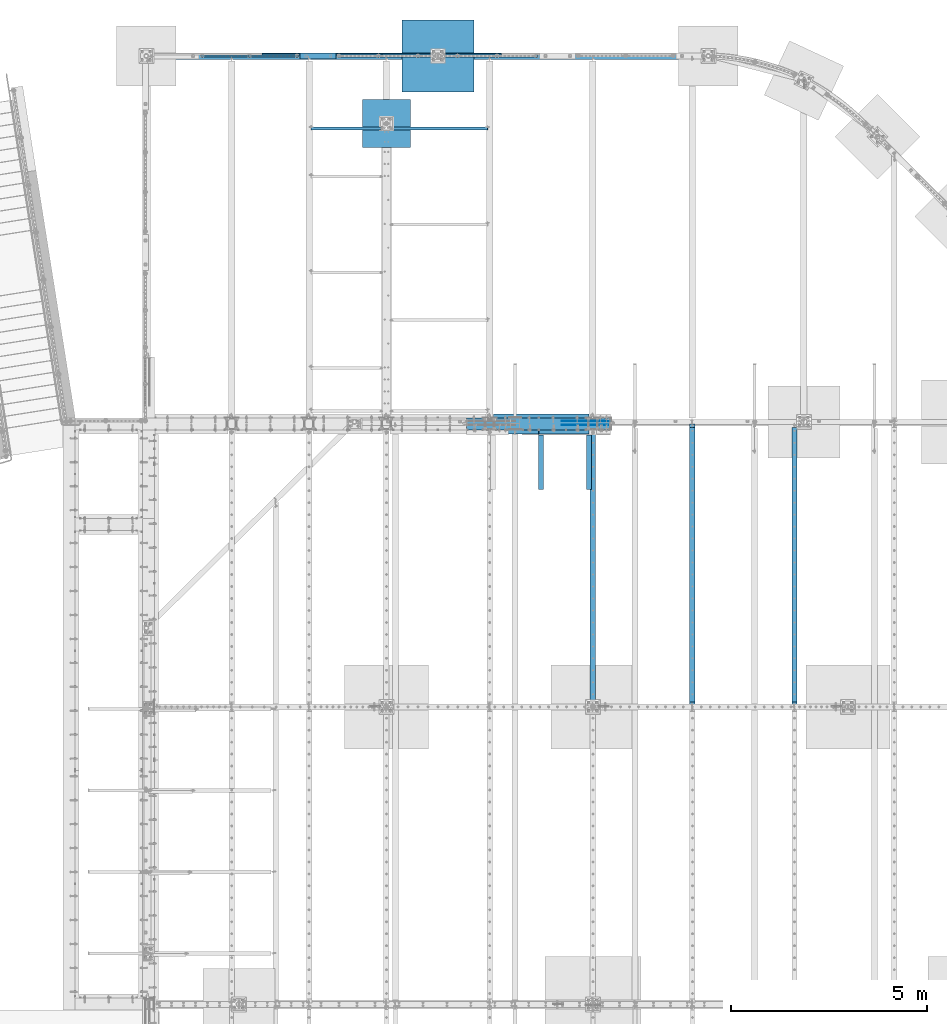
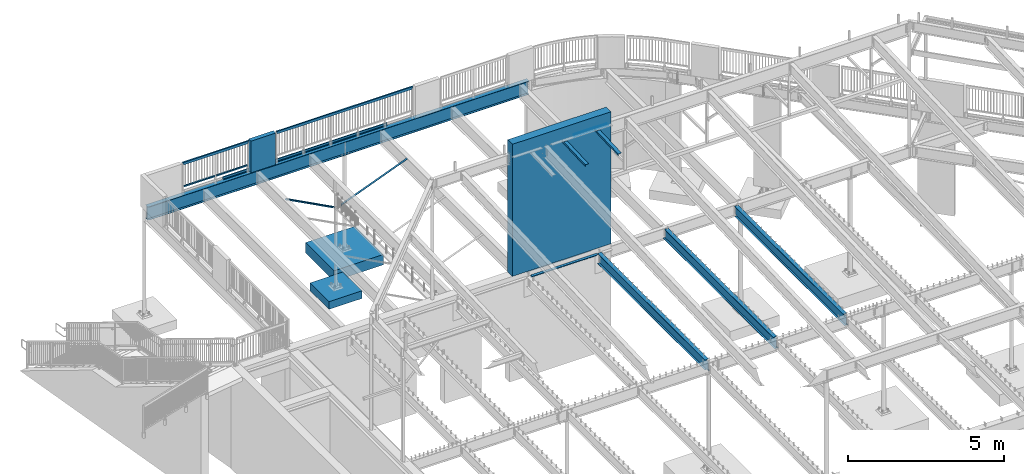
# One storey, part 325 of 975: 23 beams.
"""IFC2X3 building model written with IfcOpenShell, lengths in millimetres."""

from ifc_helpers import new_model, si_unit, frame, origin_with_axes, place, context, subcontext, project, spatial, faceted_brep, material, type_object, element, save


model = new_model("IFC2X3")

# Units and contexts
model_context = context("Model", 3, precision=1e-05, world=origin_with_axes())
body_context = subcontext(model_context, "Body", "Model", "MODEL_VIEW")
ifc_project = project(units=[si_unit("LENGTHUNIT", "METRE", prefix="MILLI"), si_unit("AREAUNIT", "SQUARE_METRE"), si_unit("VOLUMEUNIT", "CUBIC_METRE"), si_unit("MASSUNIT", "GRAM", prefix="KILO"), si_unit("TIMEUNIT", "SECOND"), si_unit("PLANEANGLEUNIT", "RADIAN"), si_unit("SOLIDANGLEUNIT", "STERADIAN"), si_unit("THERMODYNAMICTEMPERATUREUNIT", "DEGREE_CELSIUS"), si_unit("LUMINOUSINTENSITYUNIT", "LUMEN")], contexts=[model_context])

# Site, building, storey
site_placement = place(None, origin_with_axes())
site = spatial("IfcSite", under=ifc_project, at=site_placement, CompositionType="ELEMENT")
building_placement = place(site_placement, origin_with_axes())
building = spatial("IfcBuilding", under=site, at=building_placement, Name="Undefined", CompositionType="ELEMENT")
storey_placement = place(building_placement, origin_with_axes())
storey = spatial("IfcBuildingStorey", under=building, at=storey_placement, Name="Undefined", CompositionType="ELEMENT", Elevation=0.0)

# Beams
ifc_material_1 = material(Name="STEEL/A36")
beam_type_1 = type_object("IfcBeamType", Name="L3X3X3/16", PredefinedType="NOTDEFINED")
beam_1_placement = place(storey_placement, frame((8064.5, 28112.24375, 2870.2), z_axis=(-0.999999999999998, 6.90000001668524e-08, 0.0), x_axis=(0.0, 0.0, 1.0)))
element("IfcBeam", 1, at=beam_1_placement, inside=storey, type_object=beam_type_1, material=ifc_material_1, Name="ANGLE", ObjectType="L3X3X3/16", context=body_context, shape_type="Brep", body=[
    faceted_brep([(46.1799589858119, 38.0999999999985, 38.1000000000004), (46.1799589858119, 33.3375000000015, 38.1000000000004), (972.720343066658, 33.3375000000015, 1789.57301067668), (972.720343066658, 38.0999999999985, 1789.57301067668), (26.0603826014149, 38.0999999999985, 0.0672324894812846), (26.0603826014149, 33.3375000000015, 0.0672324894812846), (89.2065642251332, 38.0999999999985, -33.3374999984389), (89.2065642251332, 33.3375000000015, -33.3374999984389), (1035.86652469034, 33.3375000000015, 1756.16827818882), (89.2065642281518, -38.0999999999985, -33.3374999999996), (1035.86652469042, -38.0999999999985, 1756.16827818877), (25.4000000000001, -38.0999999999985, -33.3374999999996), (25.4000000000001, -38.0999999999985, -38.1000000000004), (92.0750045776413, -38.0999999999985, -38.1000000000004), (1040.07627013201, -38.0999999999985, 1753.94129602291), (92.0750045776413, 38.0999999999985, -38.1000000000004), (25.4000000000001, 38.0999999999985, -38.1000000000004), (1040.07627013201, 38.0999999999985, 1753.94129602291), (25.4000000000001, 38.0999999999985, -33.337499282643), (25.4000000000001, 33.3375000000015, -33.3374999999996)], [[[0, 1, 2, 3]], [[1, 0, 4, 5]], [[5, 4, 6, 7]], [[1, 5, 7, 8, 2]], [[7, 9, 10, 8]], [[9, 11, 12, 13, 14, 10]], [[15, 13, 12, 16]], [[13, 15, 17, 14]], [[3, 2, 8, 10, 14, 17]], [[15, 16, 18, 6, 4, 0, 3, 17]], [[7, 6, 18, 19]], [[16, 12, 11, 19, 18]], [[9, 7, 19, 11]]]),
])
beam_2_placement = place(storey_placement, frame((8394.7, 28112.24375, 2870.2), z_axis=(0.0, -1.0, 0.0), x_axis=(0.0, 0.0, 1.0)))
element("IfcBeam", 2, at=beam_2_placement, inside=storey, type_object=beam_type_1, material=ifc_material_1, Name="ANGLE", ObjectType="L3X3X3/16", context=body_context, shape_type="Brep", body=[
    faceted_brep([(39.9761162779782, -38.1000000000186, -33.3375000000015), (39.9761162779782, -38.1000000000186, -38.0999999999985), (975.885837340196, -2441.28615210523, -38.0999999999985), (975.885837340196, -2441.28615210523, -33.3375000000015), (92.0750045805971, 38.0999999999585, 38.0999999999985), (92.0750045776413, 38.0999999999985, -38.1000000000004), (25.4000000000001, 38.0999999999985, -38.1000000000004), (25.4000000005876, 38.0999999999876, 38.0999999999985), (1046.89123738925, -2413.6334277571, 38.0999999999985), (1046.89123738925, -2413.6334277571, -38.0999999999985), (22.2348571728535, 7.45519597605016, -38.0999999999985), (88.8737698161085, 33.4074081533654, -38.0999999999985), (25.4037304659755, 33.357482595593, -38.0999999999985), (88.8737698161085, 33.4074081533654, -33.3375000000015), (22.2348571728535, 7.45519597605016, -33.3375000000015), (25.4037304659819, 33.3574825875421, -33.3375000000015), (25.4037304659746, 33.3574825966371, 38.0999999999985), (88.8188240616832, 33.3374999999596, 38.0999999999985), (1042.45405198512, -2415.36146907195, -33.3375000000015), (1042.45339988618, -2415.36172302886, 38.0999999999985)], [[[0, 1, 2, 3]], [[4, 5, 6, 7]], [[5, 4, 8, 9]], [[1, 10, 11, 12, 6, 5, 9, 2]], [[13, 11, 10, 14]], [[11, 13, 15, 12]], [[16, 7, 6, 12, 15]], [[13, 17, 16, 15]], [[17, 13, 18, 19]], [[4, 7, 16, 17, 19, 8]], [[18, 3, 2, 9, 8, 19]], [[13, 14, 0, 3, 18]], [[10, 1, 0, 14]]]),
])
ifc_material_2 = material()
beam_type_2 = type_object("IfcBeamType", Name="HSS2X2X.188_TUBES", PredefinedType="NOTDEFINED")
beam_3_placement = place(storey_placement, frame((4746.62715136731, 29961.6867937508, 4229.09979176158), z_axis=(4.55899999906251e-06, 0.999999999989608, 0.0), x_axis=(0.999999999989593, -4.55899999895318e-06, 1.72999999958954e-07)))
element("IfcBeam", 3, at=beam_3_placement, inside=storey, type_object=beam_type_2, material=ifc_material_2, Name="HANDRAIL", ObjectType="HSS2X2X.188_TUBES", context=body_context, shape_type="Brep", body=[
    faceted_brep([(25.3999997357314, 20.6374999999898, -20.6374999999998), (25.4001244344508, -20.6375000000044, -20.6375000000025), (1181.10374119046, -20.6375000005246, -20.6374999983855), (1181.10373404989, 20.637499999475, -20.6374999983527), (25.3998894558863, -20.6375000000044, 20.6375), (1181.10355301781, -20.6375000005255, 20.6375000015942), (25.3999075342581, 20.6374999999998, 20.6375000000003), (1181.10354587724, 20.637499999475, 20.6375000016269), (25.4000643904665, 25.3999999999887, -25.3999999999287), (25.3998825073104, 25.4000000000005, 25.4000000000005), (1181.1035233411, 25.3999999994758, 25.4000000016276), (1181.10375493821, 25.3999999994758, -25.3999999983462), (25.3998602570064, -25.4000000000033, 25.4000000000001), (1181.1035321295, -25.4000000005253, 25.4000000015876), (25.4001494613913, -25.4000000000042, -25.4000000000028), (1181.10376372661, -25.4000000005253, -25.3999999983862)], [[[0, 1, 2, 3]], [[1, 4, 5, 2]], [[4, 6, 7, 5]], [[6, 0, 3, 7]], [[8, 9, 10, 11]], [[9, 12, 13, 10]], [[12, 14, 15, 13]], [[14, 8, 11, 15]], [[13, 15, 11, 10], [5, 7, 3, 2]], [[14, 12, 9, 8], [6, 4, 1, 0]]]),
])
beam_4_placement = place(storey_placement, frame((3540.12495572627, 29961.6977934874, 4229.10021524384), z_axis=(4.55899999906251e-06, 0.999999999989608, 0.0), x_axis=(0.999999999989593, -4.55899999895318e-06, 1.72999999958954e-07)))
element("IfcBeam", 4, at=beam_4_placement, inside=storey, type_object=beam_type_2, material=ifc_material_2, Name="HANDRAIL", ObjectType="HSS2X2X.188_TUBES", context=body_context, shape_type="Brep", body=[
    faceted_brep([(25.4001425128263, 20.6374999999998, -20.6375000000021), (25.4001244344508, -20.6375000000044, -20.6375000000025), (1181.10227410721, -20.6374999995523, -20.6374999983345), (1181.10225396503, 20.6375000004509, -20.6374999983964), (25.3998894558863, -20.6375000000044, 20.6375), (1181.10208593455, -20.6374999995523, 20.6375000016451), (25.3999075342581, 20.6374999999998, 20.6375000000003), (1181.10206579236, 20.6375000004509, 20.6375000015796), (25.4001717116989, 25.3999999999996, -25.4000000000026), (25.3998825073104, 25.4000000000005, 25.4000000000005), (1181.10204175603, 25.4000000004507, 25.4000000015731), (1181.10227335317, 25.4000000004507, -25.3999999984007), (25.3998602570064, -25.4000000000033, 25.4000000000001), (1181.10206654641, -25.3999999995522, 25.4000000016531), (25.4001494613913, -25.4000000000042, -25.4000000000028), (1181.10229814354, -25.3999999995522, -25.3999999983207)], [[[0, 1, 2, 3]], [[1, 4, 5, 2]], [[4, 6, 7, 5]], [[6, 0, 3, 7]], [[8, 9, 10, 11]], [[9, 12, 13, 10]], [[12, 14, 15, 13]], [[14, 8, 11, 15]], [[13, 15, 11, 10], [5, 7, 3, 2]], [[14, 12, 9, 8], [6, 4, 1, 0]]]),
])
beam_type_3 = type_object("IfcBeamType", Name="HSS2X4X.188_TUBES", PredefinedType="NOTDEFINED")
beam_5_placement = place(storey_placement, frame((3540.124968888, 29961.8003208815, 5130.8), z_axis=(0.0, 0.0, 1.0), x_axis=(0.999999998764607, -4.97069999879304e-05, -1.40000005822416e-08)))
element("IfcBeam", 5, at=beam_5_placement, inside=storey, type_object=beam_type_3, material=ifc_material_2, Name="GUARDRAIL", ObjectType="HSS2X4X.188_TUBES", context=body_context, shape_type="Brep", body=[
    faceted_brep([(23.0198915490837, 20.6374999999994, -46.0375000000031), (23.0198915283145, -20.6374999999966, -46.0375000000085), (2389.98594351881, -20.6375000042608, -46.0375000000004), (2389.98594351874, 20.6374999957952, -46.0375000000004), (-23.0198845522937, -20.6374999999985, 46.0375000000058), (2436.02571436495, -20.6375000043408, 46.0375000000004), (-23.0198845315244, 20.6374999999973, 46.0375000000113), (2436.02571436488, 20.6374999957152, 46.0375000000004), (25.4012592797953, 25.399999999999, -50.8000000000029), (-25.4012522574303, 25.3999999999967, 50.800000000012), (2438.40708182243, 25.3999999957196, 50.8000000000002), (2387.60457606117, 25.3999999958141, -50.8000000000002), (-25.401252282998, -25.3999999999983, 50.8000000000056), (2438.40708182252, -25.4000000043561, 50.8000000000002), (25.401259254224, -25.399999999996, -50.8000000000102), (2387.60457606126, -25.4000000042615, -50.8000000000002)], [[[0, 1, 2, 3]], [[1, 4, 5, 2]], [[4, 6, 7, 5]], [[6, 0, 3, 7]], [[8, 9, 10, 11]], [[9, 12, 13, 10]], [[12, 14, 15, 13]], [[14, 8, 11, 15]], [[13, 15, 11, 10], [5, 7, 3, 2]], [[14, 12, 9, 8], [6, 4, 1, 0]]]),
])
beam_6_placement = place(storey_placement, frame((7019.92795603858, 29962.444542395, 5130.79170626117), z_axis=(0.0, 0.0, 1.0), x_axis=(0.999999996531638, -8.32869999612161e-05, 0.0)))
element("IfcBeam", 6, at=beam_6_placement, inside=storey, type_object=beam_type_3, material=ifc_material_2, Name="GUARDRAIL", ObjectType="HSS2X4X.188_TUBES", context=body_context, shape_type="Brep", body=[
    faceted_brep([(23.0206677038004, 20.6375000000444, -46.0375000000004), (23.0206677037631, -20.6375000000116, -46.0375000000004), (5006.17935668326, -20.6374999959335, -46.0375000000004), (5006.1793566833, 20.6375000041226, -46.0375000000004), (-23.0206664766065, -20.6375000000517, 46.0375000000004), (5052.22069086364, -20.6374999958971, 46.0375000000004), (-23.0206664765683, 20.637500000008, 46.0375000000004), (5052.22069086367, 20.6375000041589, 46.0375000000004), (25.4021160234788, 25.4000000000524, -50.8000000000002), (-25.4021147962385, 25.4000000000087, 50.8000000000002), (5054.60213918335, 25.4000000041669, 50.8000000000002), (5003.79790836363, 25.4000000041269, -50.8000000000002), (-25.4021147962858, -25.4000000000597, 50.8000000000002), (5054.6021391833, -25.3999999959015, 50.8000000000002), (25.4021160234333, -25.4000000000196, -50.8000000000002), (5003.79790836359, -25.3999999959415, -50.8000000000002)], [[[0, 1, 2, 3]], [[1, 4, 5, 2]], [[4, 6, 7, 5]], [[6, 0, 3, 7]], [[8, 9, 10, 11]], [[9, 12, 13, 10]], [[12, 14, 15, 13]], [[14, 8, 11, 15]], [[13, 15, 11, 10], [5, 7, 3, 2]], [[14, 12, 9, 8], [6, 4, 1, 0]]]),
])
beam_type_4 = type_object("IfcBeamType", PredefinedType="NOTDEFINED")
for number, where, z_axis, x_axis, name in (
    (7, (9636.20341487034, 29987.8750007629, 3938.58749694824), (1.0, 0.0, 0.0), (0.0, 1.0, 0.0), "DECK_EDGE"),
    (8, (6588.20341487034, 29987.8750007629, 3938.58749694824), (1.0, 0.0, 0.0), (0.0, 1.0, 0.0), "DECK_EDGE"),
):
    element("IfcBeam", number, at=place(storey_placement, frame(where, z_axis=z_axis, x_axis=x_axis)), inside=storey, type_object=beam_type_4, material=ifc_material_1, Name=name, context=body_context, shape_type="Brep", body=[
        faceted_brep([(1.03318598121405e-09, -1.58750000000009, -1524.00000000109), (-1.04046193882823e-09, -1.58750000000009, 1524.0000000011), (-1.04046193882823e-09, 1.58750000000009, 1524.0000000011), (1.03318598121405e-09, 1.58750000000009, -1524.00000000109), (47.6250001214066, 1.58750000000009, 1524.00000000113), (47.6250001235167, 1.58750000000009, -1524.00000000107), (50.8000001235196, -1.58750000000009, -1524.00000000106), (50.8000001214168, -1.58750000000009, 1524.00000000113), (47.6250001214503, 96.837499999901, 1524.00000000113), (47.625000123473, 96.8374999999951, -1524.00000000106), (50.8000001234759, 104.502628762961, -1524.00000000106), (50.8000001214605, 104.502628762867, 1524.00000000113), (38.6447461584321, 87.8572448731024, 1524.00000000113), (38.6447461604548, 87.8572448731024, -1524.00000000107), (36.3996819826862, 90.102308757891, 1524.00000000112), (36.3996819847016, 90.102308757891, -1524.00000000107)], [[[0, 1, 2, 3]], [[3, 2, 4, 5]], [[1, 0, 6, 7]], [[5, 4, 8, 9]], [[7, 6, 10, 11]], [[9, 8, 12, 13]], [[8, 4, 2, 1, 7, 11, 14, 12]], [[11, 10, 15, 14]], [[10, 6, 0, 3, 5, 9, 13, 15]], [[14, 15, 13, 12]]]),
    ])
ifc_material_3 = material(Name="CONCRETE/5000")
beam_type_5 = type_object("IfcBeamType", PredefinedType="NOTDEFINED")
beam_7_placement = place(storey_placement, frame((6028.87677609106, 29962.4750000005, 4559.3), z_axis=(0.0, 0.0, 1.0), x_axis=(1.0, 0.0, 0.0)))
element("IfcBeam", 9, at=beam_7_placement, inside=storey, type_object=beam_type_5, material=ifc_material_3, Name="LOW WALL", context=body_context, shape_type="Brep", body=[
    faceted_brep([(1.0550138540566e-10, 76.1999999999316, -622.3), (1.0550138540566e-10, 76.1999999999316, 622.3), (914.399999999998, 76.1999999999998, 622.3), (914.399999999998, 76.1999999999998, -622.3), (-1.01863406598568e-10, -76.1999999999243, 622.3), (914.399999999998, -76.2, 622.3), (-1.01863406598568e-10, -76.1999999999243, -622.3), (914.399999999998, -76.2, -622.3)], [[[0, 1, 2, 3]], [[1, 4, 5, 2]], [[4, 6, 7, 5]], [[6, 0, 3, 7]], [[5, 7, 3, 2]], [[6, 4, 1, 0]]]),
])
beam_type_6 = type_object("IfcBeamType", Name="L4X4X5/16", PredefinedType="NOTDEFINED")
for number, where, z_axis, x_axis, name in (
    (10, (13392.149999995, 20799.4249996637, 3886.2), (0.0, 1.0, 0.0), (-0.999999999999998, 6.90000001668524e-08, 0.0), "LEDGER_ANGLE"),
    (11, (10953.7499999909, 20393.025, 3886.2), (0.0, -1.0, 0.0), (1.0, 0.0, 0.0), "LEDGER_ANGLE"),
):
    element("IfcBeam", number, at=place(storey_placement, frame(where, z_axis=z_axis, x_axis=x_axis)), inside=storey, type_object=beam_type_6, material=ifc_material_1, Name=name, ObjectType="L4X4X5/16", context=body_context, shape_type="Brep", body=[
        faceted_brep([(-1.90993887372315e-11, 50.8000000000002, -50.8), (2.00088834390044e-11, 50.8000000000002, 50.8), (2438.40000000415, 50.8000000000002, 50.7999999999993), (2438.40000000415, 50.8000000000002, -50.7999999999993), (2.00088834390044e-11, 42.8625000000002, 50.8), (2438.40000000415, 42.8625000000002, 50.7999999999993), (-1.63709046319127e-11, 42.8625000000002, -42.8625), (2438.40000000415, 42.8625000000002, -42.8624999999993), (-1.63709046319127e-11, -50.8000000000002, -42.8625), (2438.40000000415, -50.8000000000002, -42.8624999999993), (-1.90993887372315e-11, -50.8000000000002, -50.8), (2438.40000000415, -50.8000000000002, -50.7999999999993)], [[[0, 1, 2, 3]], [[1, 4, 5, 2]], [[4, 6, 7, 5]], [[6, 8, 9, 7]], [[8, 10, 11, 9]], [[10, 0, 3, 11]], [[5, 7, 9, 11, 3, 2]], [[10, 8, 6, 4, 1, 0]]]),
    ])
beam_type_7 = type_object("IfcBeamType", Name="L5X3X5/16", PredefinedType="NOTDEFINED")
for number, where, z_axis, x_axis, name in (
    (12, (13384.2125, 18922.6835815429, 8738.420951846), (1.0, 0.0, 0.0), (0.0, 0.999153014665285, 0.0411491589862177), "ANGLE"),
    (13, (12165.0125, 18922.6835815429, 8738.42095184597), (1.0, 0.0, 0.0), (0.0, 0.999153014665285, 0.0411491589862177), "ANGLE"),
):
    element("IfcBeam", number, at=place(storey_placement, frame(where, z_axis=z_axis, x_axis=x_axis)), inside=storey, type_object=beam_type_7, material=ifc_material_1, Name=name, ObjectType="L5X3X5/16", context=body_context, shape_type="Brep", body=[
        faceted_brep([(1395.30358400897, 38.0999999993073, 63.5), (1394.97671549211, 30.1624999993064, 63.5), (1394.97670561824, 30.1624999993055, -55.5625), (1394.97670495998, 30.1624990542159, -63.5), (1395.30357345898, 38.0999999993073, -63.5), (1501.24906497065, 25.7857737940658, -55.5625), (1501.24906431239, 25.785773821176, -63.5), (1513.41947380123, 12.5737820912245, -55.5625), (1513.41947314297, 12.5737821183347, -63.5), (1511.34756340183, -38.1000000007598, -55.5625), (1511.34756274358, -38.1000000007589, -63.5), (5.0931703299284e-11, -38.0999999999999, -63.5000000000255), (2.27373675443232e-12, -38.1000000000313, -55.5624999999873), (3.41060513164848e-12, 30.1624999999367, -55.5625000000091), (-3.63797880709171e-12, 30.1625000000404, 63.4999999999909), (-4.72937244921923e-11, 38.0999999999999, 63.5000000000182), (5.0931703299284e-11, 38.0999999999999, -63.5000000000255)], [[[0, 1, 2, 3, 4]], [[5, 6, 3, 2]], [[7, 8, 6, 5]], [[9, 10, 8, 7]], [[11, 12, 13, 14, 15, 16]], [[14, 13, 2, 1]], [[15, 14, 1, 0]], [[16, 15, 0, 4]], [[11, 16, 4, 3, 6, 8, 10]], [[12, 11, 10, 9]], [[2, 13, 12, 9, 7, 5]]]),
    ])
ifc_material_4 = material(Name="STEEL/A496")
beam_type_8 = type_object("IfcBeamType", Name="#6 DBA", PredefinedType="NOTDEFINED")
for number, where, z_axis, x_axis, name in (
    (14, (13909.6749909893, 20672.4250016253, 8707.44741323086), (0.0, 1.0, 0.0), (-0.999999999999998, 6.90000001668524e-08, 0.0), "ROD"),
    (15, (13909.6749905832, 20570.8250016253, 8707.44741324703), (0.0, 1.0, 0.0), (-0.999999999999998, 6.90000001668524e-08, 0.0), "ROD"),
    (16, (13909.6749909893, 20672.4250016075, 8618.54742535521), (0.0, 1.0, 0.0), (-0.999999999999998, 6.90000001668524e-08, 0.0), "ROD"),
):
    element("IfcBeam", number, at=place(storey_placement, frame(where, z_axis=z_axis, x_axis=x_axis)), inside=storey, type_object=beam_type_8, material=ifc_material_4, Name=name, ObjectType="#6 DBA", context=body_context, shape_type="Brep", body=[
        faceted_brep([(0.0, -6.34999999998763, -3.63797880709171e-12), (0.0, -4.49012806052269, -4.49012806054634), (1219.19983372321, -4.49012806053543, -4.49012805836537), (1219.19983372321, -6.35000000000036, 2.16823536902666e-09), (0.0, 7.27595761418343e-12, -6.35000000000764), (1219.19983372321, 0.0, -6.34999999783395), (0.0, 4.49012806053724, -4.49012806053906), (1219.19983372321, 4.49012806053543, -4.49012805836537), (0.0, 6.34999999999491, 5.45696821063757e-12), (1219.19983372321, 6.35000000000036, 2.16823536902666e-09), (0.0, 4.49012806052633, 4.49012806054634), (1219.19983372321, 4.49012806053543, 4.49012806270184), (0.0, 0.0, 6.35000000000764), (1219.19983372321, 0.0, 6.35000000216678), (0.0, -4.49012806053361, 4.49012806053543), (1219.19983372321, -4.49012806053543, 4.49012806270184)], [[[0, 1, 2, 3]], [[1, 4, 5, 2]], [[4, 6, 7, 5]], [[6, 8, 9, 7]], [[8, 10, 11, 9]], [[10, 12, 13, 11]], [[12, 14, 15, 13]], [[14, 0, 3, 15]], [[5, 7, 9, 11, 13, 15, 3, 2]], [[14, 12, 10, 8, 6, 4, 1, 0]]]),
    ])
ifc_material_5 = material(Name="STEEL/A992")
beam_type_9 = type_object("IfcBeamType", Name="W16X26", PredefinedType="NOTDEFINED")
beam_8_placement = place(storey_placement, frame((18618.2, 13392.15, 3736.975), z_axis=(0.0, 0.0, 1.0), x_axis=(0.0, 1.0, 0.0)))
element("IfcBeam", 17, at=beam_8_placement, inside=storey, type_object=beam_type_9, material=ifc_material_5, Name="BEAM", ObjectType="W16X26", context=body_context, shape_type="Brep", body=[
    faceted_brep([(7098.61634971727, -3.17499999999927, -190.5), (7098.61634971727, -69.8499999999985, -190.5), (7098.61634971727, -69.8499999999985, -200.025), (7098.61634971727, 69.8499999999985, -200.025), (7098.61634971727, 69.8499999999985, -190.5), (7098.61634971727, 3.17499999999927, -190.5), (7098.61634971727, 3.17499999999927, -187.324999809266), (7098.61634971727, -3.17499999999927, -187.324999809266), (7099.58307963985, 3.17499999999927, -182.46492029122), (7099.58307963985, -3.17499999999927, -182.46492029122), (7102.33609354033, 3.17499999999927, -178.344743823066), (7102.33609354033, -3.17499999999927, -178.344743823066), (7106.45627000849, 3.17499999999927, -175.591729922588), (7106.45627000849, -3.17499999999927, -175.591729922588), (7111.31634952653, 3.17499999999927, -174.625), (7111.31634952653, -3.17499999999927, -174.625), (7200.21634971727, -3.17499999999927, -174.625), (7200.21634971727, 3.17499999999927, -174.625), (7111.31634971726, 69.8499999999985, 190.5), (7111.31634971726, 3.17499999999927, 190.5), (118.268749999994, 3.17499999999927, 190.5), (118.268749999994, 69.8499999999985, 190.5), (29.368749999996, 3.17499999999927, -190.5), (29.368749999996, 69.8499999999985, -190.5), (29.368749999996, 69.8499999999985, -200.025), (29.368749999996, -69.8499999999985, -200.025), (29.368749999996, -69.8499999999985, -190.5), (29.368749999996, -3.17499999999927, -190.5), (29.368749999996, -3.17499999999927, 174.625), (29.368749999996, 3.17499999999927, 174.625), (105.568750190729, -3.17499999999927, 174.625), (105.568750190729, 3.17499999999927, 174.625), (110.428829708775, -3.17499999999927, 175.591729922588), (110.428829708775, 3.17499999999927, 175.591729922588), (114.549006176929, -3.17499999999927, 178.344743823066), (114.549006176929, 3.17499999999927, 178.344743823066), (117.302020077406, -3.17499999999927, 182.46492029122), (117.302020077406, 3.17499999999927, 182.46492029122), (118.268749999994, -3.17499999999927, 187.324999809266), (118.268749999994, 3.17499999999927, 187.324999809266), (118.268749999994, -69.8499999999985, 200.024999810586), (118.268749999994, 69.8499999999985, 200.025), (118.268749999994, -3.17499999999927, 190.5), (118.268749999994, -69.8499999999985, 190.5), (7111.31634971726, -3.17499999999927, 190.5), (7111.31634971726, -69.8499999999985, 190.5), (7111.31634971726, -69.8499999999985, 200.025), (7111.31634971726, 69.8499999999985, 200.025), (7111.31634971726, -3.17499999999927, 187.324999809265), (7111.31634971726, 3.17499999999927, 187.324999809265), (7112.28307963985, -3.17499999999927, 182.464920291219), (7112.28307963985, 3.17499999999927, 182.464920291219), (7115.03609354033, -3.17499999999927, 178.344743823066), (7115.03609354033, 3.17499999999927, 178.344743823066), (7119.15627000848, -3.17499999999927, 175.591729922588), (7119.15627000848, 3.17499999999927, 175.591729922588), (7124.01634952653, -3.17499999999927, 174.625), (7124.01634952653, 3.17499999999927, 174.625), (7200.21634971727, -3.17499999999927, 174.625), (7200.21634971727, 3.17499999999927, 174.625)], [[[0, 1, 2, 3, 4, 5, 6, 7]], [[7, 6, 8, 9]], [[9, 8, 10, 11]], [[11, 10, 12, 13]], [[13, 12, 14, 15]], [[16, 15, 14, 17]], [[18, 19, 20, 21]], [[22, 23, 24, 25, 26, 27, 28, 29]], [[30, 31, 29, 28]], [[32, 33, 31, 30]], [[34, 35, 33, 32]], [[36, 37, 35, 34]], [[38, 39, 37, 36]], [[40, 41, 21, 20, 39, 38, 42, 43]], [[44, 45, 43, 42]], [[45, 46, 40, 43]], [[46, 47, 41, 40]], [[47, 18, 21, 41]], [[46, 45, 44, 48, 49, 19, 18, 47]], [[50, 51, 49, 48]], [[52, 53, 51, 50]], [[54, 55, 53, 52]], [[56, 57, 55, 54]], [[58, 59, 57, 56]], [[59, 58, 16, 17]], [[12, 10, 8, 6, 5, 22, 29, 31, 33, 35, 37, 39, 20, 19, 49, 51, 53, 55, 57, 59, 17, 14]], [[23, 22, 5, 4]], [[24, 23, 4, 3]], [[25, 24, 3, 2]], [[26, 25, 2, 1]], [[27, 26, 1, 0]], [[58, 56, 54, 52, 50, 48, 44, 42, 38, 36, 34, 32, 30, 28, 27, 0, 7, 9, 11, 13, 15, 16]]]),
])
beam_9_placement = place(storey_placement, frame((16021.05, 13392.15, 3736.975), z_axis=(0.0, 0.0, 1.0), x_axis=(0.0, 1.0, 0.0)))
element("IfcBeam", 18, at=beam_9_placement, inside=storey, type_object=beam_type_9, material=ifc_material_5, Name="BEAM", ObjectType="W16X26", context=body_context, shape_type="Brep", body=[
    faceted_brep([(105.568750190729, -3.17499999999927, 174.625), (105.568750190729, 3.17499999999927, 174.625), (29.368749999996, 3.17499999999927, 174.625), (29.368749999996, -3.17499999999927, 174.625), (110.428829708775, -3.17499999999927, 175.591729922588), (110.428829708775, 3.17499999999927, 175.591729922588), (114.549006176929, -3.17499999999927, 178.344743823066), (114.549006176929, 3.17499999999927, 178.344743823066), (117.302020077406, -3.17499999999927, 182.46492029122), (117.302020077406, 3.17499999999927, 182.46492029122), (118.268749999994, -3.17499999999927, 187.324999809266), (118.268749999994, 3.17499999999927, 187.324999809266), (118.268749999994, -69.8499999999985, 200.024999810586), (118.268749999994, 69.8499999999985, 200.025), (118.268749999994, 69.8499999999985, 190.5), (118.268749999994, 3.17499999999927, 190.5), (118.268749999994, -3.17499999999927, 190.5), (118.268749999994, -69.8499999999985, 190.5), (29.368749999996, -3.17499999999927, -190.5), (29.368749999996, -69.8499999999985, -190.5), (7200.21634971727, -69.8499999999985, -190.5), (7200.21634971727, -3.17499999999927, -190.5), (29.368749999996, -69.8499999999985, -200.025), (7200.21634971727, -69.8499999999985, -200.025), (29.368749999996, 69.8499999999985, -200.025), (7200.21634971727, 69.8499999999985, -200.025), (29.368749999996, 69.8499999999985, -190.5), (7200.21634971727, 69.8499999999985, -190.5), (29.368749999996, 3.17499999999927, -190.5), (7200.21634971727, 3.17499999999927, -190.5), (7200.21634971727, 3.17499999999927, 174.625), (7200.21634971727, -3.17499999999927, 174.625), (7124.01634952653, 3.17499999999927, 174.625), (7124.01634952653, -3.17499999999927, 174.625), (7119.15627000848, 3.17499999999927, 175.591729922588), (7119.15627000848, -3.17499999999927, 175.591729922588), (7115.03609354033, 3.17499999999927, 178.344743823066), (7115.03609354033, -3.17499999999927, 178.344743823066), (7112.28307963985, 3.17499999999927, 182.464920291219), (7112.28307963985, -3.17499999999927, 182.464920291219), (7111.31634971726, 3.17499999999927, 187.324999809265), (7111.31634971726, -3.17499999999927, 187.324999809265), (7111.31634971726, -69.8499999999985, 200.025), (7111.31634971726, -69.8499999999985, 190.5), (7111.31634971726, -3.17499999999927, 190.5), (7111.31634971726, 3.17499999999927, 190.5), (7111.31634971726, 69.8499999999985, 190.5), (7111.31634971726, 69.8499999999985, 200.025)], [[[0, 1, 2, 3]], [[4, 5, 1, 0]], [[6, 7, 5, 4]], [[8, 9, 7, 6]], [[10, 11, 9, 8]], [[12, 13, 14, 15, 11, 10, 16, 17]], [[18, 19, 20, 21]], [[19, 22, 23, 20]], [[22, 24, 25, 23]], [[24, 26, 27, 25]], [[26, 28, 29, 27]], [[21, 20, 23, 25, 27, 29, 30, 31]], [[31, 30, 32, 33]], [[33, 32, 34, 35]], [[35, 34, 36, 37]], [[37, 36, 38, 39]], [[39, 38, 40, 41]], [[42, 43, 44, 41, 40, 45, 46, 47]], [[43, 42, 12, 17]], [[44, 43, 17, 16]], [[8, 6, 4, 0, 3, 18, 21, 31, 33, 35, 37, 39, 41, 44, 16, 10]], [[28, 26, 24, 22, 19, 18, 3, 2]], [[45, 40, 38, 36, 34, 32, 30, 29, 28, 2, 1, 5, 7, 9, 11, 15]], [[46, 45, 15, 14]], [[47, 46, 14, 13]], [[42, 47, 13, 12]]]),
])
beam_10_placement = place(storey_placement, frame((13487.4, 13392.15, 3736.975), z_axis=(0.0, 0.0, 1.0), x_axis=(0.0, 1.0, 0.0)))
element("IfcBeam", 19, at=beam_10_placement, inside=storey, type_object=beam_type_9, material=ifc_material_5, Name="BEAM", ObjectType="W16X26", context=body_context, shape_type="Brep", body=[
    faceted_brep([(29.368749999996, -3.17499999999927, -190.5), (29.368749999996, -69.8499999999985, -190.5), (7026.275, -69.8500000000004, -190.5), (7026.275, -3.17499999999927, -190.5), (29.368749999996, -69.8499999999985, -200.025), (7026.275, -69.8500000000004, -200.025), (7026.275, 3.17499999999927, -190.5), (7026.275, 3.17499999999927, 190.5), (7026.275, 69.8500000000004, 190.5), (7026.275, 69.8500000000004, 200.025), (7026.275, -69.8500000000004, 200.025), (7026.275, -69.8500000000004, 190.5), (7026.275, -3.17499999999927, 190.5), (7026.275, 69.8500000000004, -200.025), (7026.275, 69.8500000000004, -190.5), (124.618750000001, 69.8500000000004, -200.025), (124.618750000001, 69.8500000000004, -190.5), (124.618750000001, 3.77549991607884, -200.025), (124.618750000001, 3.77549991607884, -190.5), (29.3687499999996, 3.77549991607884, -200.025), (29.3687499999996, 3.77549991607884, -190.5), (29.368749999996, 3.17499999999927, -190.5), (110.428829708775, -3.17499999999927, 175.591729922588), (110.428829708775, 3.17499999999927, 175.591729922588), (105.568750190729, 3.17499999999927, 174.625), (105.568750190729, -3.17499999999927, 174.625), (114.549006176929, -3.17499999999927, 178.344743823066), (114.549006176929, 3.17499999999927, 178.344743823066), (117.302020077406, -3.17499999999927, 182.46492029122), (117.302020077406, 3.17499999999927, 182.46492029122), (118.268749999994, -3.17499999999927, 187.324999809266), (118.268749999994, 3.17499999999927, 187.324999809266), (29.368749999996, 3.17499999999927, 174.625), (118.268749999994, 3.17499999999927, 190.5), (118.268749999994, 69.8499999999985, 190.5), (118.268749999994, 69.8499999999985, 200.025), (118.268749999994, -69.8499999999985, 200.024999810586), (118.268749999994, -69.8499999999985, 190.5), (118.268749999994, -3.17499999999927, 190.5), (29.368749999996, -3.17499999999927, 174.625)], [[[0, 1, 2, 3]], [[1, 4, 5, 2]], [[6, 7, 8, 9, 10, 11, 12, 3, 2, 5, 13, 14]], [[14, 13, 15, 16]], [[16, 15, 17, 18]], [[13, 5, 4, 19, 17, 15]], [[18, 17, 19, 20]], [[21, 6, 14, 16, 18, 20]], [[22, 23, 24, 25]], [[26, 27, 23, 22]], [[28, 29, 27, 26]], [[30, 31, 29, 28]], [[7, 6, 21, 32, 24, 23, 27, 29, 31, 33]], [[8, 7, 33, 34]], [[9, 8, 34, 35]], [[10, 9, 35, 36]], [[11, 10, 36, 37]], [[12, 11, 37, 38]], [[36, 35, 34, 33, 31, 30, 38, 37]], [[28, 26, 22, 25, 39, 0, 3, 12, 38, 30]], [[21, 20, 19, 4, 1, 0, 39, 32]], [[25, 24, 32, 39]]]),
])
beam_type_10 = type_object("IfcBeamType", PredefinedType="NOTDEFINED")
beam_11_placement = place(storey_placement, frame((13928.725, 20596.225, 6705.6), z_axis=(0.0, 0.0, 1.0), x_axis=(-0.999999999999998, 6.90000001668524e-08, 0.0)))
element("IfcBeam", 20, at=beam_11_placement, inside=storey, type_object=beam_type_10, material=ifc_material_3, Name="WALL", context=body_context, shape_type="Brep", body=[
    faceted_brep([(0.0, 152.400000000001, -2590.8), (0.0, 152.400000000001, 2590.8), (3654.425, 152.400000000001, 2590.8), (3654.425, 152.400000000001, -2590.8), (0.0, -152.400000000001, 2590.8), (3654.425, -152.400000000001, 2590.8), (0.0, -152.400000000001, -2590.8), (3654.425, -152.400000000001, -2590.8)], [[[0, 1, 2, 3]], [[1, 4, 5, 2]], [[4, 6, 7, 5]], [[6, 0, 3, 7]], [[5, 7, 3, 2]], [[6, 4, 1, 0]]]),
])
beam_type_11 = type_object("IfcBeamType", PredefinedType="NOTDEFINED")
beam_12_placement = place(storey_placement, frame((7620.00000846571, 28241.625023622, -457.2), z_axis=(0.0, 0.0, 1.0), x_axis=(1.0, 0.0, 0.0)))
element("IfcBeam", 21, at=beam_12_placement, inside=storey, type_object=beam_type_11, material=ifc_material_3, Name="FOOTING", context=body_context, shape_type="Brep", body=[
    faceted_brep([(1.62981450557709e-09, 609.600000000892, -152.4), (1.62981450557709e-09, 609.600000000892, 152.4), (1219.20000000183, 609.600000002347, 152.4), (1219.20000000183, 609.600000002347, -152.4), (-1.61526259034872e-09, -609.600000000886, 152.4), (1219.19999999859, -609.599999999426, 152.4), (-1.61526259034872e-09, -609.600000000886, -152.4), (1219.19999999859, -609.599999999426, -152.4)], [[[0, 1, 2, 3]], [[1, 4, 5, 2]], [[4, 6, 7, 5]], [[6, 0, 3, 7]], [[5, 7, 3, 2]], [[6, 4, 1, 0]]]),
])
beam_type_12 = type_object("IfcBeamType", PredefinedType="NOTDEFINED")
beam_13_placement = place(storey_placement, frame((8626.47500846572, 29962.475023622, -508.0), z_axis=(0.0, 0.0, 1.0), x_axis=(1.0, 0.0, 0.0)))
element("IfcBeam", 22, at=beam_13_placement, inside=storey, type_object=beam_type_12, material=ifc_material_3, Name="FOOTING", context=body_context, shape_type="Brep", body=[
    faceted_brep([(0.0, 914.400000000001, -203.2), (0.0, 914.400000000001, 203.2), (1828.8, 914.400000000001, 203.2), (1828.8, 914.400000000001, -203.2), (0.0, -914.400000000001, 203.2), (1828.8, -914.400000000001, 203.2), (0.0, -914.400000000001, -203.2), (1828.8, -914.400000000001, -203.2)], [[[0, 1, 2, 3]], [[1, 4, 5, 2]], [[4, 6, 7, 5]], [[6, 0, 3, 7]], [[5, 7, 3, 2]], [[6, 4, 1, 0]]]),
])
beam_type_13 = type_object("IfcBeamType", Name="W21X44", PredefinedType="NOTDEFINED")
beam_14_placement = place(storey_placement, frame((2143.125, 29956.125, 3675.0625), z_axis=(0.0, 0.0, 1.0), x_axis=(1.0, 0.0, 0.0)))
element("IfcBeam", 23, at=beam_14_placement, inside=storey, type_object=beam_type_13, material=ifc_material_5, Name="BEAM", ObjectType="W21X44", context=body_context, shape_type="Brep", body=[
    faceted_brep([(14198.6, -82.5499999999993, -261.9375), (14198.6, -82.5499999999993, -250.825), (88.8999969482406, -82.5499992370715, -250.825), (88.8999969482411, -82.5499999999993, -261.9375), (14198.6, -4.76250000000073, -250.825), (57.1499999999987, -4.76250000000073, -250.825), (57.1499999999987, -63.5000001179687, -250.825), (88.8999969482406, -63.5000004128633, -250.825), (57.1499999999987, -63.5000001179687, -261.9375), (88.8999969482406, -63.5000004128633, -261.9375), (57.1499999999987, 82.5499999999993, -261.9375), (14198.6, 82.5499999999993, -261.9375), (57.1499999999987, 82.5499999999993, 250.825), (57.1499999999987, 82.5499999999993, 261.9375), (14198.6, 82.5499999999993, 261.9375), (14198.6, 82.5499999999993, 250.825), (57.1499999999987, 4.76250000000073, 250.825), (14198.6, 4.76250000000073, 250.825), (57.1499999999987, 4.76250000000073, -250.825), (14198.6, 4.76250000000073, -250.825), (57.1499999999987, 82.5499999999993, -250.825), (14198.6, 82.5499999999993, -250.825), (14198.6, -82.5499999999993, 261.9375), (14198.6, -82.5499999999993, 250.825), (14198.6, -4.76250000000073, 250.825), (57.1499999999987, -4.76250000000073, 250.825), (57.1499999999987, -63.5000001179687, 250.825), (57.1499999999987, -63.5000001179687, 261.9375), (88.8999969482406, -63.5000004128633, 261.9375), (88.8999969482406, -82.5499992370715, 261.9375), (88.8999969482411, -82.5499999999993, 250.825), (88.8999969482406, -63.5000004128633, 250.825)], [[[0, 1, 2, 3]], [[1, 4, 5, 6, 7, 2]], [[6, 8, 9, 7]], [[2, 7, 9, 3]], [[8, 10, 11, 0, 3, 9]], [[12, 13, 14, 15]], [[16, 12, 15, 17]], [[18, 16, 17, 19]], [[20, 18, 19, 21]], [[10, 20, 21, 11]], [[19, 17, 15, 14, 22, 23, 24, 4, 1, 0, 11, 21]], [[25, 5, 4, 24]], [[13, 12, 16, 18, 20, 10, 8, 6, 5, 25, 26, 27]], [[22, 14, 13, 27, 28, 29]], [[23, 22, 29, 30]], [[26, 25, 24, 23, 30, 31]], [[29, 28, 31, 30]], [[27, 26, 31, 28]]]),
])

save(model, "model.ifc")
